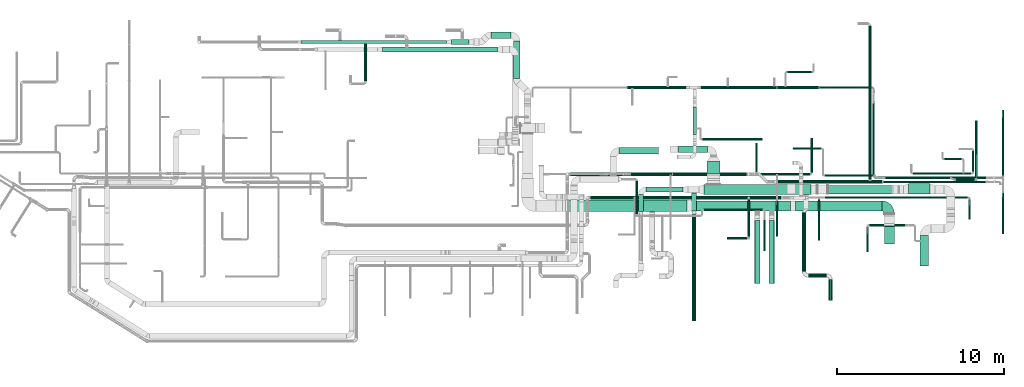
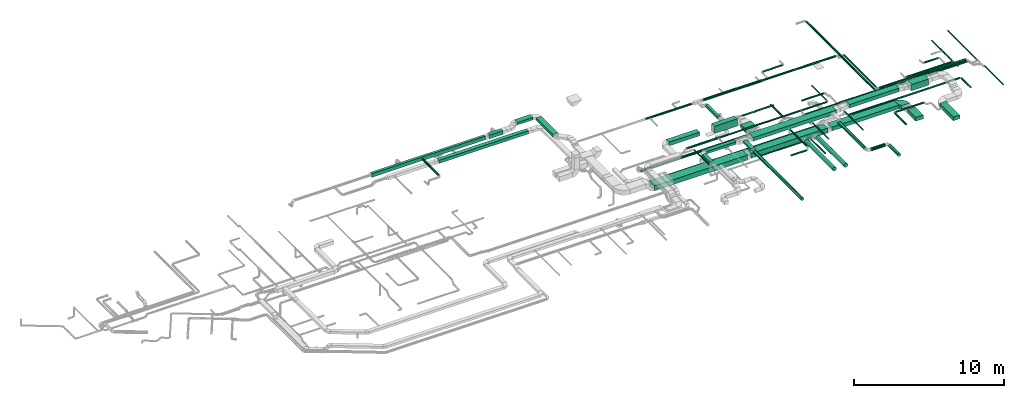
# One storey, part 3 of 60: 65 flow segments, 1 flow fitting.
"""IFC2X3 building model written with IfcOpenShell, lengths in millimetres."""

from ifc_helpers import new_model, entity, si_unit, converted_unit, derived_unit, direction, frame, frame_2d, origin, origin_2d_with_axis, place, context, subcontext, project, spatial, polyline, circle_curve, parameter, trimmed, segment, composite_curve, rectangle, circle, outline, extrude, source, transform, mapped, material, type_object, type_shapes, element, save


model = new_model("IFC2X3")

# Units and contexts
model_context = context("Model", 3, precision=0.01, world=origin(), true_north=direction((6.12303176911189e-17, 1.0)))
body_context = subcontext(model_context, "Body", "Model", "MODEL_VIEW")
ifc_project = project(units=[si_unit("LENGTHUNIT", "METRE", prefix="MILLI"), si_unit("AREAUNIT", "SQUARE_METRE"), si_unit("VOLUMEUNIT", "CUBIC_METRE"), converted_unit("PLANEANGLEUNIT", "DEGREE", entity("IfcRatioMeasure", 0.0174532925199433), si_unit("PLANEANGLEUNIT", "RADIAN"), dimensions=[0, 0, 0, 0, 0, 0, 0]), si_unit("MASSUNIT", "GRAM", prefix="KILO"), derived_unit("MASSDENSITYUNIT", [(si_unit("MASSUNIT", "GRAM", prefix="KILO"), 1), (si_unit("LENGTHUNIT", "METRE"), -3)]), derived_unit("MOMENTOFINERTIAUNIT", [(si_unit("LENGTHUNIT", "METRE"), 4)]), si_unit("TIMEUNIT", "SECOND"), si_unit("FREQUENCYUNIT", "HERTZ"), si_unit("THERMODYNAMICTEMPERATUREUNIT", "DEGREE_CELSIUS"), derived_unit("THERMALTRANSMITTANCEUNIT", [(si_unit("MASSUNIT", "GRAM", prefix="KILO"), 1), (si_unit("THERMODYNAMICTEMPERATUREUNIT", "KELVIN"), -1), (si_unit("TIMEUNIT", "SECOND"), -3)]), derived_unit("VOLUMETRICFLOWRATEUNIT", [(si_unit("LENGTHUNIT", "METRE"), 3), (si_unit("TIMEUNIT", "SECOND"), -1)]), derived_unit("MASSFLOWRATEUNIT", [(si_unit("MASSUNIT", "GRAM", prefix="KILO"), 1), (si_unit("TIMEUNIT", "SECOND"), -1)]), derived_unit("ROTATIONALFREQUENCYUNIT", [(si_unit("TIMEUNIT", "SECOND"), -1)]), si_unit("ELECTRICCURRENTUNIT", "AMPERE"), si_unit("ELECTRICVOLTAGEUNIT", "VOLT"), si_unit("POWERUNIT", "WATT"), si_unit("FORCEUNIT", "NEWTON", prefix="KILO"), si_unit("ILLUMINANCEUNIT", "LUX"), si_unit("LUMINOUSFLUXUNIT", "LUMEN"), si_unit("LUMINOUSINTENSITYUNIT", "CANDELA"), derived_unit("USERDEFINED", [(si_unit("MASSUNIT", "GRAM", prefix="KILO"), -1), (si_unit("LENGTHUNIT", "METRE"), -2), (si_unit("TIMEUNIT", "SECOND"), 3), (si_unit("LUMINOUSFLUXUNIT", "LUMEN"), 1)]), derived_unit("LINEARVELOCITYUNIT", [(si_unit("LENGTHUNIT", "METRE"), 1), (si_unit("TIMEUNIT", "SECOND"), -1)]), si_unit("PRESSUREUNIT", "PASCAL"), derived_unit("USERDEFINED", [(si_unit("LENGTHUNIT", "METRE"), -2), (si_unit("MASSUNIT", "GRAM", prefix="KILO"), 1), (si_unit("TIMEUNIT", "SECOND"), -2)]), derived_unit("LINEARFORCEUNIT", [(si_unit("MASSUNIT", "GRAM", prefix="KILO"), 1), (si_unit("LENGTHUNIT", "METRE"), 1), (si_unit("TIMEUNIT", "SECOND"), -2), (si_unit("LENGTHUNIT", "METRE"), -1)]), derived_unit("PLANARFORCEUNIT", [(si_unit("MASSUNIT", "GRAM", prefix="KILO"), 1), (si_unit("LENGTHUNIT", "METRE"), 1), (si_unit("TIMEUNIT", "SECOND"), -2), (si_unit("LENGTHUNIT", "METRE"), -2)])], contexts=[model_context])

# Site, building, storey
site_placement = place(None, origin())
site = spatial("IfcSite", under=ifc_project, at=site_placement, CompositionType="ELEMENT")
building_placement = place(site_placement, origin())
building = spatial("IfcBuilding", under=site, at=building_placement, CompositionType="ELEMENT")
storey_placement = place(building_placement, frame((0.0, 0.0, 19800.0)))
storey = spatial("IfcBuildingStorey", under=building, at=storey_placement, CompositionType="ELEMENT", Elevation=19800.0)

# Flow segments
duct_segment_type_1 = type_object("IfcDuctSegmentType", PredefinedType="NOTDEFINED")
flow_segment_1_placement = place(storey_placement, frame((49271.97, 11485.34, 3350.0)))
element("IfcFlowSegment", 1, at=flow_segment_1_placement, inside=storey, type_object=duct_segment_type_1, context=body_context, shape_type="SweptSolid", body=[
    extrude(rectangle(XDim=2353.23659249344, YDim=400.0, at=origin_2d_with_axis()), frame((1176.62, 200.0, 0.0), z_axis=(0.0, 0.0, 1.0), x_axis=(-1.0, 0.0, 0.0)), (0.0, 0.0, 1.0), 300.000000000001),
])
flow_segment_2_placement = place(storey_placement, frame((35113.67, 17600.36, 3175.0)))
element("IfcFlowSegment", 2, at=flow_segment_2_placement, inside=storey, type_object=duct_segment_type_1, context=body_context, shape_type="SweptSolid", body=[
    extrude(rectangle(XDim=6880.0, YDim=300.000000000001, at=origin_2d_with_axis()), frame((3440.0, 150.0, 0.0), z_axis=(0.0, 0.0, 1.0), x_axis=(-1.0, 0.0, 0.0)), (0.0, 0.0, 1.0), 250.000000000004),
])
flow_segment_3_placement = place(storey_placement, frame((42944.05, 16025.51, 3550.0)))
element("IfcFlowSegment", 3, at=flow_segment_3_placement, inside=storey, type_object=duct_segment_type_1, context=body_context, shape_type="SweptSolid", body=[
    extrude(rectangle(XDim=2225.02525316944, YDim=399.999999999996, at=origin_2d_with_axis()), frame((200.0, 1112.51, 0.0), z_axis=(0.0, 0.0, 1.0), x_axis=(0.0, 1.0, 0.0)), (0.0, 0.0, 1.0), 199.999999999998),
])
flow_segment_4_placement = place(storey_placement, frame((39248.07, 18050.18, 3450.0)))
element("IfcFlowSegment", 4, at=flow_segment_4_placement, inside=storey, type_object=duct_segment_type_1, context=body_context, shape_type="SweptSolid", body=[
    extrude(rectangle(XDim=1035.6249999999, YDim=300.000000000001, at=origin_2d_with_axis()), frame((517.81, 150.0, 0.0)), (0.0, 0.0, 1.0), 300.000000000001),
])
flow_segment_5_placement = place(storey_placement, frame((30228.07, 18100.18, 3450.0)))
element("IfcFlowSegment", 5, at=flow_segment_5_placement, inside=storey, type_object=duct_segment_type_1, context=body_context, shape_type="SweptSolid", body=[
    extrude(rectangle(XDim=8720.0, YDim=200.0, at=origin_2d_with_axis()), frame((4360.0, 100.0, 0.0), z_axis=(0.0, 0.0, 1.0), x_axis=(-1.0, 0.0, 0.0)), (0.0, 0.0, 1.0), 300.000000000001),
])
flow_segment_6_placement = place(storey_placement, frame((41589.03, 18400.54, 3550.0)))
element("IfcFlowSegment", 6, at=flow_segment_6_placement, inside=storey, type_object=duct_segment_type_1, context=body_context, shape_type="SweptSolid", body=[
    extrude(rectangle(XDim=1205.02525316956, YDim=400.0, at=origin_2d_with_axis()), frame((602.51, 200.0, 0.0), z_axis=(0.0, 0.0, 1.0), x_axis=(-1.0, 0.0, 0.0)), (0.0, 0.0, 1.0), 199.999999999998),
])
flow_segment_7_placement = place(storey_placement, frame((53632.16, 8089.45, 2874.9)))
element("IfcFlowSegment", 7, at=flow_segment_7_placement, inside=storey, type_object=duct_segment_type_1, context=body_context, shape_type="SweptSolid", body=[
    extrude(rectangle(XDim=5905.53318782731, YDim=600.0, at=origin_2d_with_axis()), frame((2952.77, 300.0, 0.02), z_axis=(-8.18553682062866e-06, 0.0, 1.0), x_axis=(-1.0, 0.0, -8.18553682062866e-06)), (0.0, 0.0, 1.0), 400.000000000003),
])
flow_segment_8_placement = place(storey_placement, frame((46170.61, 8039.45, 2874.9)))
element("IfcFlowSegment", 8, at=flow_segment_8_placement, inside=storey, type_object=duct_segment_type_1, context=body_context, shape_type="SweptSolid", body=[
    extrude(rectangle(XDim=7161.55050634894, YDim=700.0, at=origin_2d_with_axis()), frame((3580.78, 350.0, 0.0)), (0.0, 0.0, 1.0), 400.000000000004),
])
flow_segment_9_placement = place(storey_placement, frame((59837.69, 8089.45, 2924.9)))
element("IfcFlowSegment", 9, at=flow_segment_9_placement, inside=storey, type_object=duct_segment_type_1, context=body_context, shape_type="SweptSolid", body=[
    extrude(rectangle(XDim=5149.99999979142, YDim=600.0, at=origin_2d_with_axis()), frame((2575.0, 300.0, 0.02), z_axis=(-8.63213560550077e-06, 0.0, 1.0), x_axis=(-1.0, 0.0, -8.63213560550077e-06)), (0.0, 0.0, 1.0), 300.000000000003),
])
flow_segment_10_placement = place(storey_placement, frame((65137.69, 6099.45, 3070.0)))
element("IfcFlowSegment", 10, at=flow_segment_10_placement, inside=storey, type_object=duct_segment_type_1, context=body_context, shape_type="SweptSolid", body=[
    extrude(rectangle(XDim=1112.1482213042, YDim=600.000000000002, at=origin_2d_with_axis()), frame((300.0, 556.07, 0.0), z_axis=(0.0, 0.0, 1.0), x_axis=(0.0, -1.0, 0.0)), (0.0, 0.0, 1.0), 300.000000000001),
])
flow_segment_11_placement = place(storey_placement, frame((52820.35, 11573.78, 3050.0)))
element("IfcFlowSegment", 11, at=flow_segment_11_placement, inside=storey, type_object=duct_segment_type_1, context=body_context, shape_type="SweptSolid", body=[
    extrude(rectangle(XDim=1751.44726433125, YDim=400.0, at=origin_2d_with_axis()), frame((875.72, 200.0, 0.0)), (0.0, 0.0, 1.0), 600.000000000002),
])
flow_segment_12_placement = place(storey_placement, frame((50865.38, 9213.95, 3520.0)))
element("IfcFlowSegment", 12, at=flow_segment_12_placement, inside=storey, type_object=duct_segment_type_1, context=body_context, shape_type="SweptSolid", body=[
    extrude(rectangle(XDim=2237.49999999992, YDim=300.0, at=origin_2d_with_axis()), frame((1118.75, 150.0, 0.0)), (0.0, 0.0, 1.0), 199.999999999998),
])
flow_segment_13_placement = place(storey_placement, frame((50415.38, 8056.06, 3520.0)))
element("IfcFlowSegment", 13, at=flow_segment_13_placement, inside=storey, type_object=duct_segment_type_1, context=body_context, shape_type="SweptSolid", body=[
    extrude(rectangle(XDim=1007.89213562392, YDim=300.000000000001, at=origin_2d_with_axis()), frame((150.0, 503.95, 0.0), z_axis=(0.0, 0.0, 1.0), x_axis=(0.0, -1.0, 0.0)), (0.0, 0.0, 1.0), 199.999999999998),
])
flow_segment_14_placement = place(storey_placement, frame((53608.41, 8089.81, 3500.0)))
element("IfcFlowSegment", 14, at=flow_segment_14_placement, inside=storey, type_object=duct_segment_type_1, context=body_context, shape_type="SweptSolid", body=[
    extrude(rectangle(XDim=1054.14213562379, YDim=300.000000000001, at=origin_2d_with_axis()), frame((150.0, 527.07, 0.0), z_axis=(0.0, 0.0, 1.0), x_axis=(0.0, 1.0, 0.0)), (0.0, 0.0, 1.0), 150.000000000001),
])
flow_segment_15_placement = place(storey_placement, frame((54352.88, 9063.95, 3420.0)))
element("IfcFlowSegment", 15, at=flow_segment_15_placement, inside=storey, type_object=duct_segment_type_1, context=body_context, shape_type="SweptSolid", body=[
    extrude(rectangle(XDim=6392.61143934599, YDim=600.0, at=origin_2d_with_axis()), frame((3196.31, 300.0, 0.0)), (0.0, 0.0, 1.0), 300.000000000001),
])
flow_segment_16_placement = place(storey_placement, frame((61775.61, 9113.95, 3480.0)))
element("IfcFlowSegment", 16, at=flow_segment_16_placement, inside=storey, type_object=duct_segment_type_1, context=body_context, shape_type="SweptSolid", body=[
    extrude(rectangle(XDim=3814.80489590959, YDim=500.0, at=origin_2d_with_axis()), frame((1907.4, 250.0, 0.0)), (0.0, 0.0, 1.0), 300.000000000001),
])
flow_segment_17_placement = place(storey_placement, frame((66575.49, 9113.95, 3220.0)))
element("IfcFlowSegment", 17, at=flow_segment_17_placement, inside=storey, type_object=duct_segment_type_1, context=body_context, shape_type="SweptSolid", body=[
    extrude(rectangle(XDim=1300.00000000018, YDim=600.0, at=origin_2d_with_axis()), frame((650.0, 300.0, 0.0)), (0.0, 0.0, 1.0), 499.999999999999),
])
flow_segment_18_placement = place(storey_placement, frame((67280.49, 4786.97, 3150.0)))
element("IfcFlowSegment", 18, at=flow_segment_18_placement, inside=storey, type_object=duct_segment_type_1, context=body_context, shape_type="SweptSolid", body=[
    extrude(rectangle(XDim=1842.84271247463, YDim=499.999999999999, at=origin_2d_with_axis()), frame((250.0, 921.42, 0.0), z_axis=(0.0, 0.0, 1.0), x_axis=(0.0, -1.0, 0.0)), (0.0, 0.0, 1.0), 300.000000000001),
])
flow_segment_19_placement = place(storey_placement, frame((53690.46, 12654.29, 3250.0)))
element("IfcFlowSegment", 19, at=flow_segment_19_placement, inside=storey, type_object=duct_segment_type_1, context=body_context, shape_type="SweptSolid", body=[
    extrude(rectangle(XDim=1652.89321881347, YDim=199.999999999998, at=origin_2d_with_axis()), frame((100.0, 826.45, 0.0), z_axis=(0.0, 0.0, 1.0), x_axis=(0.0, 1.0, 0.0)), (0.0, 0.0, 1.0), 199.999999999998),
])
flow_segment_20_placement = place(storey_placement, frame((54521.8, 10339.53, 3240.0)))
element("IfcFlowSegment", 20, at=flow_segment_20_placement, inside=storey, type_object=duct_segment_type_1, context=body_context, shape_type="SweptSolid", body=[
    extrude(rectangle(XDim=694.25209514467, YDim=800.0, at=origin_2d_with_axis()), frame((400.0, 347.13, 0.0), z_axis=(0.0, 0.0, 1.0), x_axis=(0.0, 1.0, 0.0)), (0.0, 0.0, 1.0), 300.000000000001),
])
duct_segment_type_2 = type_object("IfcDuctSegmentType", PredefinedType="NOTDEFINED")
flow_segment_21_placement = place(storey_placement, frame((58738.59, 9724.4, 3448.41)))
element("IfcFlowSegment", 21, at=flow_segment_21_placement, inside=storey, type_object=duct_segment_type_2, context=body_context, shape_type="SweptSolid", body=[
    extrude(circle(Radius=100.0, at=origin_2d_with_axis()), frame((0.0, 101.6, 101.6), z_axis=(1.0, 0.0, 0.0), x_axis=(0.0, 1.0, 0.0)), (0.0, 0.0, 1.0), 6264.31457505076),
])
flow_segment_22_placement = place(storey_placement, frame((65077.9, 9761.89, 3485.91)))
element("IfcFlowSegment", 22, at=flow_segment_22_placement, inside=storey, type_object=duct_segment_type_2, context=body_context, shape_type="SweptSolid", body=[
    extrude(circle(Radius=62.5, at=origin_2d_with_axis()), frame((0.0, 64.11, 64.1), z_axis=(1.0, -2.37119331794132e-06, 0.0), x_axis=(-2.37119331794132e-06, -1.0, 0.0)), (0.0, 0.0, 1.0), 6143.22307127265),
])
flow_segment_23_placement = place(storey_placement, frame((46370.4, 10184.02, 2953.4)))
element("IfcFlowSegment", 23, at=flow_segment_23_placement, inside=storey, type_object=duct_segment_type_2, context=body_context, shape_type="SweptSolid", body=[
    extrude(circle(Radius=100.0, at=origin_2d_with_axis()), frame((0.0, 101.6, 101.6), z_axis=(1.0, 0.0, 0.0), x_axis=(0.0, 1.0, 0.0)), (0.0, 0.0, 1.0), 10512.075382968),
])
flow_segment_24_placement = place(storey_placement, frame((64198.57, 9946.01, 3468.4)))
element("IfcFlowSegment", 24, at=flow_segment_24_placement, inside=storey, type_object=duct_segment_type_2, context=body_context, shape_type="SweptSolid", body=[
    extrude(circle(Radius=80.0, at=origin_2d_with_axis()), frame((81.6, 0.0, 81.6), z_axis=(0.0, 1.0, -4.23805096326353e-07), x_axis=(1.0, 0.0, 0.0)), (0.0, 0.0, 1.0), 9194.04298459907),
])
flow_segment_25_placement = place(storey_placement, frame((50270.37, 7895.34, 3548.4)))
element("IfcFlowSegment", 25, at=flow_segment_25_placement, inside=storey, type_object=duct_segment_type_2, context=body_context, shape_type="SweptSolid", body=[
    extrude(circle(Radius=50.0, at=origin_2d_with_axis()), frame((51.6, 0.0, 51.6), z_axis=(0.0, 1.0, 0.0), x_axis=(-1.0, 0.0, 0.0)), (0.0, 0.0, 1.0), 1990.00000000006),
])
flow_segment_26_placement = place(storey_placement, frame((54321.97, 8097.5, 2748.4)))
element("IfcFlowSegment", 26, at=flow_segment_26_placement, inside=storey, type_object=duct_segment_type_2, context=body_context, shape_type="SweptSolid", body=[
    extrude(circle(Radius=50.0, at=origin_2d_with_axis()), frame((0.0, 51.6, 51.6), z_axis=(1.0, 0.0, 0.0), x_axis=(0.0, -1.0, 0.0)), (0.0, 0.0, 1.0), 3548.43750000001),
])
flow_segment_27_placement = place(storey_placement, frame((57918.81, 5695.34, 3148.4)))
element("IfcFlowSegment", 27, at=flow_segment_27_placement, inside=storey, type_object=duct_segment_type_2, context=body_context, shape_type="SweptSolid", body=[
    extrude(circle(Radius=50.0, at=origin_2d_with_axis()), frame((51.6, 0.0, 51.6), z_axis=(0.0, 1.0, 0.0), x_axis=(-1.0, 0.0, 0.0)), (0.0, 0.0, 1.0), 1862.32864376271),
])
flow_segment_28_placement = place(storey_placement, frame((60743.89, 10385.62, 3598.4)))
element("IfcFlowSegment", 28, at=flow_segment_28_placement, inside=storey, type_object=duct_segment_type_2, context=body_context, shape_type="SweptSolid", body=[
    extrude(circle(Radius=50.0, at=origin_2d_with_axis()), frame((51.6, 0.0, 51.6), z_axis=(0.0, 1.0, 0.0), x_axis=(1.0, 0.0, 0.0)), (0.0, 0.0, 1.0), 2044.68320769476),
])
flow_segment_29_placement = place(storey_placement, frame((34013.97, 15865.18, 3518.4)))
element("IfcFlowSegment", 29, at=flow_segment_29_placement, inside=storey, type_object=duct_segment_type_2, context=body_context, shape_type="SweptSolid", body=[
    extrude(circle(Radius=80.0, at=origin_2d_with_axis()), frame((81.6, 0.0, 81.6), z_axis=(0.0, 1.0, 0.0), x_axis=(-1.0, 0.0, 0.0)), (0.0, 0.0, 1.0), 2214.99999999998),
])
flow_segment_30_placement = place(storey_placement, frame((57379.82, 3739.45, 3110.9)))
element("IfcFlowSegment", 30, at=flow_segment_30_placement, inside=storey, type_object=duct_segment_type_2, context=body_context, shape_type="SweptSolid", body=[
    extrude(circle(Radius=157.5, at=origin_2d_with_axis()), frame((159.1, 0.0, 159.1), z_axis=(0.0, 1.0, 0.0), x_axis=(-1.0, 0.0, 0.0)), (0.0, 0.0, 1.0), 3769.52272785244),
])
flow_segment_31_placement = place(storey_placement, frame((58242.69, 3739.45, 3110.9)))
element("IfcFlowSegment", 31, at=flow_segment_31_placement, inside=storey, type_object=duct_segment_type_2, context=body_context, shape_type="SweptSolid", body=[
    extrude(circle(Radius=157.5, at=origin_2d_with_axis()), frame((159.1, 0.0, 159.1), z_axis=(0.0, 1.0, 0.0), x_axis=(-1.0, 0.0, 0.0)), (0.0, 0.0, 1.0), 3769.52272785248),
])
flow_segment_32_placement = place(storey_placement, frame((53631.82, 1489.81, 3398.4)))
element("IfcFlowSegment", 32, at=flow_segment_32_placement, inside=storey, type_object=duct_segment_type_2, context=body_context, shape_type="SweptSolid", body=[
    extrude(circle(Radius=125.0, at=origin_2d_with_axis()), frame((126.6, 0.0, 126.6), z_axis=(0.0, 1.0, 0.0), x_axis=(-1.0, 0.0, 0.0)), (0.0, 0.0, 1.0), 6400.0),
])
flow_segment_33_placement = place(storey_placement, frame((60216.77, 4474.68, 3373.4)))
element("IfcFlowSegment", 33, at=flow_segment_33_placement, inside=storey, type_object=duct_segment_type_2, context=body_context, shape_type="SweptSolid", body=[
    extrude(circle(Radius=125.0, at=origin_2d_with_axis()), frame((126.6, 0.0, 126.6), z_axis=(0.0, 1.0, 0.0), x_axis=(1.0, 0.0, 0.0)), (0.0, 0.0, 1.0), 3515.0),
])
flow_segment_34_placement = place(storey_placement, frame((60593.37, 4098.08, 3373.4)))
element("IfcFlowSegment", 34, at=flow_segment_34_placement, inside=storey, type_object=duct_segment_type_2, context=body_context, shape_type="SweptSolid", body=[
    extrude(circle(Radius=125.0, at=origin_2d_with_axis()), frame((0.0, 126.6, 126.6), z_axis=(1.0, 0.0, 0.0), x_axis=(0.0, -1.0, 0.0)), (0.0, 0.0, 1.0), 1080.00000000001),
])
flow_segment_35_placement = place(storey_placement, frame((61796.77, 2724.68, 3373.4)))
element("IfcFlowSegment", 35, at=flow_segment_35_placement, inside=storey, type_object=duct_segment_type_2, context=body_context, shape_type="SweptSolid", body=[
    extrude(circle(Radius=125.0, at=origin_2d_with_axis()), frame((126.6, 0.0, 126.6), z_axis=(0.0, 1.0, 0.0), x_axis=(-1.0, 0.0, 0.0)), (0.0, 0.0, 1.0), 1250.0),
])
flow_segment_36_placement = place(storey_placement, frame((54181.09, 15374.14, 2848.4)))
element("IfcFlowSegment", 36, at=flow_segment_36_placement, inside=storey, type_object=duct_segment_type_2, context=body_context, shape_type="SweptSolid", body=[
    extrude(circle(Radius=100.0, at=origin_2d_with_axis()), frame((0.0, 101.6, 101.6), z_axis=(1.0, 0.0, 0.0), x_axis=(0.0, -1.0, 0.0)), (0.0, 0.0, 1.0), 4520.0),
])
flow_segment_37_placement = place(storey_placement, frame((58741.09, 15394.14, 2868.4)))
element("IfcFlowSegment", 37, at=flow_segment_37_placement, inside=storey, type_object=duct_segment_type_2, context=body_context, shape_type="SweptSolid", body=[
    extrude(circle(Radius=80.0, at=origin_2d_with_axis()), frame((0.0, 81.6, 81.6), z_axis=(1.0, 0.0, 0.0), x_axis=(0.0, -1.0, 0.0)), (0.0, 0.0, 1.0), 2479.99999999999),
])
flow_segment_38_placement = place(storey_placement, frame((61256.09, 15411.64, 2885.9)))
element("IfcFlowSegment", 38, at=flow_segment_38_placement, inside=storey, type_object=duct_segment_type_2, context=body_context, shape_type="SweptSolid", body=[
    extrude(circle(Radius=62.5, at=origin_2d_with_axis()), frame((0.0, 64.1, 64.1), z_axis=(1.0, 0.0, 0.0), x_axis=(0.0, -1.0, 0.0)), (0.0, 0.0, 1.0), 3120.0),
])
flow_segment_39_placement = place(storey_placement, frame((64436.99, 10200.43, 3485.9)))
element("IfcFlowSegment", 39, at=flow_segment_39_placement, inside=storey, type_object=duct_segment_type_2, context=body_context, shape_type="SweptSolid", body=[
    extrude(circle(Radius=62.5, at=origin_2d_with_axis()), frame((64.1, 0.0, 64.1), z_axis=(0.0, 1.0, -8.9914757388605e-07), x_axis=(-1.0, 0.0, 0.0)), (0.0, 0.0, 1.0), 4333.52920686459),
])
flow_segment_40_placement = place(storey_placement, frame((64626.09, 10011.33, 3485.91)))
element("IfcFlowSegment", 40, at=flow_segment_40_placement, inside=storey, type_object=duct_segment_type_2, context=body_context, shape_type="SweptSolid", body=[
    extrude(circle(Radius=62.5, at=origin_2d_with_axis()), frame((0.0, 64.1, 64.1), z_axis=(1.0, 0.0, 0.0), x_axis=(0.0, -1.0, 0.0)), (0.0, 0.0, 1.0), 6618.22308186667),
])
flow_segment_41_placement = place(storey_placement, frame((49761.09, 15394.14, 2868.4)))
element("IfcFlowSegment", 41, at=flow_segment_41_placement, inside=storey, type_object=duct_segment_type_2, context=body_context, shape_type="SweptSolid", body=[
    extrude(circle(Radius=80.0, at=origin_2d_with_axis()), frame((0.0, 81.6, 81.6), z_axis=(1.0, 0.0, 0.0), x_axis=(0.0, 1.0, 0.0)), (0.0, 0.0, 1.0), 3520.00000000001),
])
flow_segment_42_placement = place(storey_placement, frame((72189.46, 10190.73, 3048.29)))
element("IfcFlowSegment", 42, at=flow_segment_42_placement, inside=storey, type_object=duct_segment_type_2, context=body_context, shape_type="SweptSolid", body=[
    extrude(circle(Radius=50.0, at=origin_2d_with_axis()), frame((51.6, 0.0, 51.6), z_axis=(0.0, 1.0, 8.91330265773193e-07), x_axis=(1.0, 0.0, 0.0)), (0.0, 0.0, 1.0), 3935.00000201904),
])
flow_segment_43_placement = place(storey_placement, frame((72189.46, 6710.73, 3148.4)))
element("IfcFlowSegment", 43, at=flow_segment_43_placement, inside=storey, type_object=duct_segment_type_2, context=body_context, shape_type="SweptSolid", body=[
    extrude(circle(Radius=50.0, at=origin_2d_with_axis()), frame((51.6, 0.0, 51.6), z_axis=(0.0, 1.0, 0.0), x_axis=(-1.0, 0.0, 0.0)), (0.0, 0.0, 1.0), 2463.57864376269),
])
flow_segment_44_placement = place(storey_placement, frame((59322.0, 16349.14, 2848.4)))
element("IfcFlowSegment", 44, at=flow_segment_44_placement, inside=storey, type_object=duct_segment_type_2, context=body_context, shape_type="SweptSolid", body=[
    extrude(circle(Radius=50.0, at=origin_2d_with_axis()), frame((0.0, 51.6, 51.6), z_axis=(1.0, 0.0, 0.0), x_axis=(0.0, -1.0, 0.0)), (0.0, 0.0, 1.0), 1488.75),
])
flow_segment_45_placement = place(storey_placement, frame((54231.71, 12321.76, 3078.4)))
element("IfcFlowSegment", 45, at=flow_segment_45_placement, inside=storey, type_object=duct_segment_type_2, context=body_context, shape_type="SweptSolid", body=[
    extrude(circle(Radius=50.0, at=origin_2d_with_axis()), frame((0.0, 51.6, 51.6), z_axis=(1.0, 0.0, 0.0), x_axis=(0.0, -1.0, 0.0)), (0.0, 0.0, 1.0), 3598.75),
])
flow_segment_46_placement = place(storey_placement, frame((47570.56, 8768.41, 2978.4)))
element("IfcFlowSegment", 46, at=flow_segment_46_placement, inside=storey, type_object=duct_segment_type_2, context=body_context, shape_type="SweptSolid", body=[
    extrude(circle(Radius=100.0, at=origin_2d_with_axis()), frame((0.0, 101.6, 101.6), z_axis=(1.0, 0.0, 0.0), x_axis=(0.0, -1.0, 0.0)), (0.0, 0.0, 1.0), 11393.4949947849),
])
flow_segment_47_placement = place(storey_placement, frame((61585.62, 8840.3, 3098.4)))
element("IfcFlowSegment", 47, at=flow_segment_47_placement, inside=storey, type_object=duct_segment_type_2, context=body_context, shape_type="SweptSolid", body=[
    extrude(circle(Radius=50.0, at=origin_2d_with_axis()), frame((0.0, 51.6, 51.6), z_axis=(1.0, 0.0, 0.0), x_axis=(0.0, 1.0, 0.0)), (0.0, 0.0, 1.0), 8548.57864376271),
])
flow_segment_48_placement = place(storey_placement, frame((70182.6, 7581.89, 3098.4)))
element("IfcFlowSegment", 48, at=flow_segment_48_placement, inside=storey, type_object=duct_segment_type_2, context=body_context, shape_type="SweptSolid", body=[
    extrude(circle(Radius=50.0, at=origin_2d_with_axis()), frame((51.6, 0.0, 51.6), z_axis=(0.0, 1.0, 0.0), x_axis=(-1.0, 0.0, 0.0)), (0.0, 0.0, 1.0), 1210.00000000002),
])
flow_segment_49_placement = place(storey_placement, frame((56974.72, 6550.36, 3548.4)))
element("IfcFlowSegment", 49, at=flow_segment_49_placement, inside=storey, type_object=duct_segment_type_2, context=body_context, shape_type="SweptSolid", body=[
    extrude(circle(Radius=50.0, at=origin_2d_with_axis()), frame((51.6, 0.0, 51.6), z_axis=(0.0, 1.0, 0.0), x_axis=(1.0, 0.0, 0.0)), (0.0, 0.0, 1.0), 2229.64185339947),
])
flow_segment_50_placement = place(storey_placement, frame((55746.32, 6398.77, 3318.4)))
element("IfcFlowSegment", 50, at=flow_segment_50_placement, inside=storey, type_object=duct_segment_type_2, context=body_context, shape_type="SweptSolid", body=[
    extrude(circle(Radius=50.0, at=origin_2d_with_axis()), frame((0.0, 51.6, 51.6), z_axis=(1.0, 0.0, 0.0), x_axis=(0.0, 1.0, 0.0)), (0.0, 0.0, 1.0), 1180.00000000002),
])
flow_segment_51_placement = place(storey_placement, frame((64230.0, 7178.57, 3408.4)))
element("IfcFlowSegment", 51, at=flow_segment_51_placement, inside=storey, type_object=duct_segment_type_2, context=body_context, shape_type="SweptSolid", body=[
    extrude(circle(Radius=50.0, at=origin_2d_with_axis()), frame((0.0, 51.6, 51.6), z_axis=(1.0, 0.0, 0.0), x_axis=(0.0, -1.0, 0.0)), (0.0, 0.0, 1.0), 2158.57864376267),
])
flow_segment_52_placement = place(storey_placement, frame((64078.4, 5635.17, 3408.4)))
element("IfcFlowSegment", 52, at=flow_segment_52_placement, inside=storey, type_object=duct_segment_type_2, context=body_context, shape_type="SweptSolid", body=[
    extrude(circle(Radius=50.0, at=origin_2d_with_axis()), frame((51.6, 0.0, 51.6), z_axis=(0.0, 1.0, 0.0), x_axis=(-1.0, 0.0, 0.0)), (0.0, 0.0, 1.0), 1495.00000000001),
])
flow_segment_53_placement = place(storey_placement, frame((59675.69, 11762.61, 3148.4)))
element("IfcFlowSegment", 53, at=flow_segment_53_placement, inside=storey, type_object=duct_segment_type_2, context=body_context, shape_type="SweptSolid", body=[
    extrude(circle(Radius=50.0, at=origin_2d_with_axis()), frame((0.0, 51.6, 51.6), z_axis=(1.0, 0.0, 0.0), x_axis=(0.0, -1.0, 0.0)), (0.0, 0.0, 1.0), 1695.10742336589),
])
flow_segment_54_placement = place(storey_placement, frame((69407.02, 9897.61, 3448.4)))
element("IfcFlowSegment", 54, at=flow_segment_54_placement, inside=storey, type_object=duct_segment_type_2, context=body_context, shape_type="SweptSolid", body=[
    extrude(circle(Radius=50.0, at=origin_2d_with_axis()), frame((0.0, 51.6, 51.6), z_axis=(1.0, 0.0, 0.0), x_axis=(0.0, -1.0, 0.0)), (0.0, 0.0, 1.0), 1133.7779326283),
])
flow_segment_55_placement = place(storey_placement, frame((70589.2, 10049.2, 3198.4)))
element("IfcFlowSegment", 55, at=flow_segment_55_placement, inside=storey, type_object=duct_segment_type_2, context=body_context, shape_type="SweptSolid", body=[
    extrude(circle(Radius=50.0, at=origin_2d_with_axis()), frame((51.6, 0.0, 51.6), z_axis=(0.0, 1.0, 0.0), x_axis=(1.0, 0.0, 0.0)), (0.0, 0.0, 1.0), 3425.00000000003),
])
flow_segment_56_placement = place(storey_placement, frame((70403.76, 10434.99, 3448.4)))
element("IfcFlowSegment", 56, at=flow_segment_56_placement, inside=storey, type_object=duct_segment_type_2, context=body_context, shape_type="SweptSolid", body=[
    extrude(circle(Radius=50.0, at=origin_2d_with_axis()), frame((51.6, 0.0, 51.6), z_axis=(0.0, 1.0, 0.0), x_axis=(1.0, 0.0, 0.0)), (0.0, 0.0, 1.0), 1260.00000000001),
])
flow_segment_57_placement = place(storey_placement, frame((66856.61, 10283.4, 3448.4)))
element("IfcFlowSegment", 57, at=flow_segment_57_placement, inside=storey, type_object=duct_segment_type_2, context=body_context, shape_type="SweptSolid", body=[
    extrude(circle(Radius=50.0, at=origin_2d_with_axis()), frame((0.0, 51.6, 51.6), z_axis=(1.0, 0.0, 0.0), x_axis=(0.0, 1.0, 0.0)), (0.0, 0.0, 1.0), 3498.74999999998),
])
flow_segment_58_placement = place(storey_placement, frame((68713.63, 11138.4, 3448.4)))
element("IfcFlowSegment", 58, at=flow_segment_58_placement, inside=storey, type_object=duct_segment_type_2, context=body_context, shape_type="SweptSolid", body=[
    extrude(circle(Radius=50.0, at=origin_2d_with_axis()), frame((0.0, 51.6, 51.6), z_axis=(1.0, 0.0, 0.0), x_axis=(0.0, 1.0, 0.0)), (0.0, 0.0, 1.0), 1067.98174960309),
])
flow_segment_59_placement = place(storey_placement, frame((61570.8, 10152.61, 3265.78)))
element("IfcFlowSegment", 59, at=flow_segment_59_placement, inside=storey, type_object=duct_segment_type_2, context=body_context, shape_type="SweptSolid", body=[
    extrude(circle(Radius=50.0, at=origin_2d_with_axis()), frame((0.0, 51.6, 51.6), z_axis=(1.0, 0.0, 0.0), x_axis=(0.0, -1.0, 0.0)), (0.0, 0.0, 1.0), 2950.72229688439),
])
flow_segment_60_placement = place(storey_placement, frame((61187.66, 6330.01, 3548.4)))
element("IfcFlowSegment", 60, at=flow_segment_60_placement, inside=storey, type_object=duct_segment_type_2, context=body_context, shape_type="SweptSolid", body=[
    extrude(circle(Radius=50.0, at=origin_2d_with_axis()), frame((51.6, 0.0, 51.6), z_axis=(0.0, 1.0, 0.0), x_axis=(1.0, 0.0, 0.0)), (0.0, 0.0, 1.0), 2461.90395016015),
])
flow_segment_61_placement = place(storey_placement, frame((49955.48, 10221.52, 3585.9)))
element("IfcFlowSegment", 61, at=flow_segment_61_placement, inside=storey, type_object=duct_segment_type_2, context=body_context, shape_type="SweptSolid", body=[
    extrude(circle(Radius=62.5, at=origin_2d_with_axis()), frame((0.0, 64.1, 64.1), z_axis=(1.0, 0.0, 0.0), x_axis=(0.0, -1.0, 0.0)), (0.0, 0.0, 1.0), 2502.22330470337),
])
flow_segment_62_placement = place(storey_placement, frame((52482.7, 10234.02, 3598.4)))
element("IfcFlowSegment", 62, at=flow_segment_62_placement, inside=storey, type_object=duct_segment_type_2, context=body_context, shape_type="SweptSolid", body=[
    extrude(circle(Radius=50.0, at=origin_2d_with_axis()), frame((0.0, 51.6, 51.6), z_axis=(1.0, 0.0, 0.0), x_axis=(0.0, 1.0, 0.0)), (0.0, 0.0, 1.0), 8212.78513463384),
])
flow_segment_63_placement = place(storey_placement, frame((58664.18, 6566.32, 3552.97)))
element("IfcFlowSegment", 63, at=flow_segment_63_placement, inside=storey, type_object=duct_segment_type_2, context=body_context, shape_type="SweptSolid", body=[
    extrude(circle(Radius=50.0, at=origin_2d_with_axis()), frame((51.6, 0.0, 51.6), z_axis=(0.0, 1.0, 0.0), x_axis=(1.0, 0.0, 0.0)), (0.0, 0.0, 1.0), 2117.1572875254),
])
flow_segment_64_placement = place(storey_placement, frame((57441.95, 10405.62, 3374.56)))
element("IfcFlowSegment", 64, at=flow_segment_64_placement, inside=storey, type_object=duct_segment_type_2, context=body_context, shape_type="SweptSolid", body=[
    extrude(circle(Radius=50.0, at=origin_2d_with_axis()), frame((51.6, 0.0, 51.6), z_axis=(0.0, 1.0, 0.0), x_axis=(1.0, 0.0, 0.0)), (0.0, 0.0, 1.0), 1740.0),
])
flow_segment_65_placement = place(storey_placement, frame((65192.32, 10000.98, 3206.42)))
element("IfcFlowSegment", 65, at=flow_segment_65_placement, inside=storey, type_object=duct_segment_type_2, context=body_context, shape_type="SweptSolid", body=[
    extrude(circle(Radius=50.0, at=origin_2d_with_axis()), frame((0.0, 51.23, 51.23), z_axis=(1.0, 0.0, 0.0), x_axis=(0.0, 0.920330918458452, 0.391140640344905)), (0.0, 0.0, 1.0), 3884.60029080666),
])

# Flow fitting
ifc_material = material()
duct_fitting_type = type_object("IfcDuctFittingType", PredefinedType="NOTDEFINED", material=ifc_material)
shared_shape = source(origin(), body_context, "Body", "SweptSolid", [
    extrude(outline(composite_curve([segment(polyline([(-525.0, -225.0), (75.0, -225.0)]), True, "CONTINUOUS"), segment(trimmed(circle_curve(frame_2d((225.0, -225.0), x_axis=(0.0, 1.0)), 150.0), [parameter(0.0)], [parameter(90.0)], True, "PARAMETER"), False, "CONTINUOUS"), segment(polyline([(225.0, -75.0), (225.0, 525.0)]), True, "CONTINUOUS"), segment(trimmed(circle_curve(frame_2d((225.0, -225.0), x_axis=(0.0, 1.0)), 750.0), [parameter(0.0)], [parameter(90.0)], True, "PARAMETER"), True, "CONTINUOUS")], self_intersect=False)), frame((-225.0, 225.0, -150.0), z_axis=(0.0, 0.0, 1.0), x_axis=(-1.0, 0.0, 0.0)), (0.0, 0.0, 1.0), 300.0),
])
type_shapes(duct_fitting_type, [shared_shape])
flow_fitting_placement = place(storey_placement, frame((65437.69, 8389.45, 3074.95), z_axis=(-8.63213559558548e-06, 0.0, 1.0), x_axis=(0.0, 1.0, 0.0)))
element("IfcFlowFitting", 66, at=flow_fitting_placement, inside=storey, type_object=duct_fitting_type, material=ifc_material, context=body_context, shape_type="MappedRepresentation", body=[
    mapped(shared_shape, transform((0.0, 0.0, 0.0), scale=1.0)),
])

save(model, "model.ifc")
